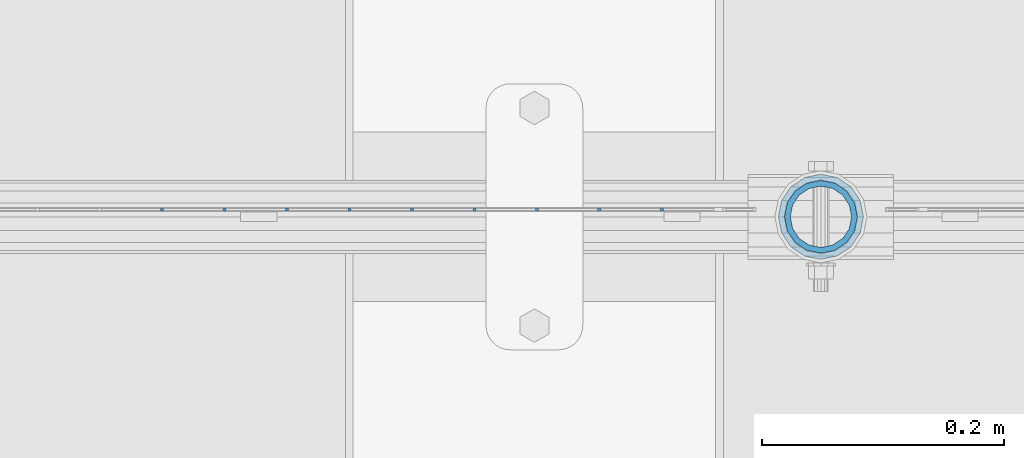
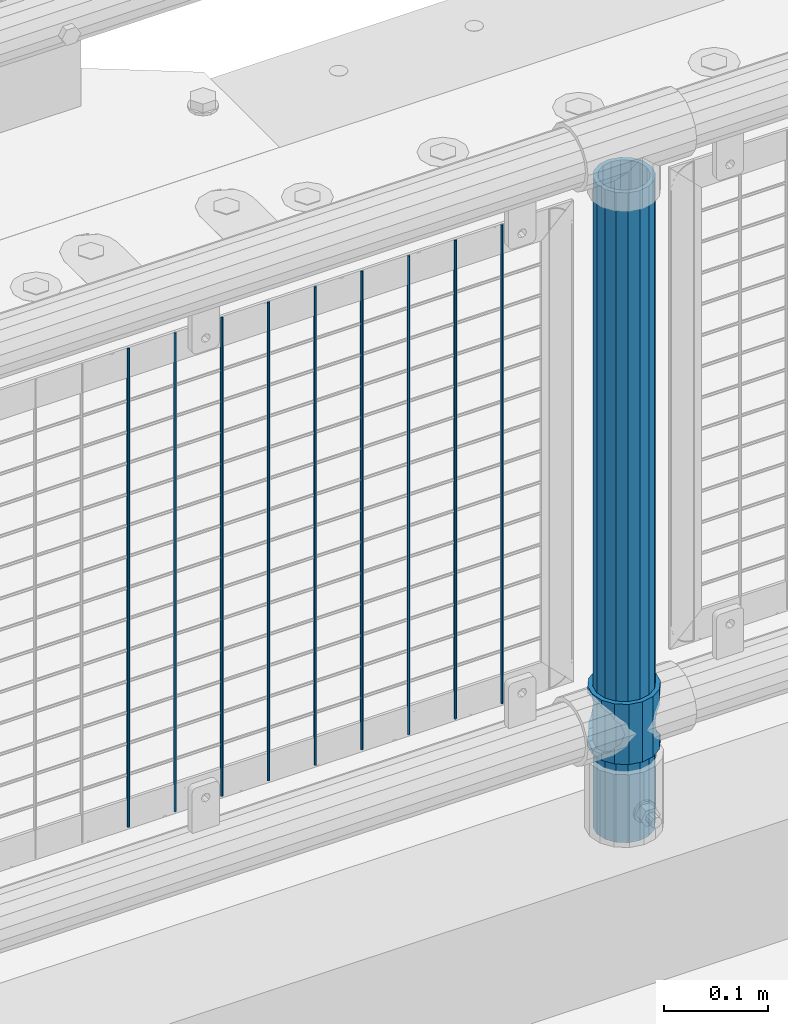
# One storey, part 72 of 240: 11 columns.
"""IFC2X3 building model written with IfcOpenShell, lengths in millimetres."""

from ifc_helpers import new_model, si_unit, frame, origin_with_axes, place, context, subcontext, project, spatial, faceted_brep, material, type_object, element, save


model = new_model("IFC2X3")

# Units and contexts
model_context = context("Model", 3, precision=1e-05, world=origin_with_axes())
body_context = subcontext(model_context, "Body", "Model", "MODEL_VIEW")
ifc_project = project(units=[si_unit("LENGTHUNIT", "METRE", prefix="MILLI"), si_unit("AREAUNIT", "SQUARE_METRE"), si_unit("VOLUMEUNIT", "CUBIC_METRE"), si_unit("MASSUNIT", "GRAM", prefix="KILO"), si_unit("TIMEUNIT", "SECOND"), si_unit("PLANEANGLEUNIT", "RADIAN"), si_unit("SOLIDANGLEUNIT", "STERADIAN"), si_unit("THERMODYNAMICTEMPERATUREUNIT", "DEGREE_CELSIUS"), si_unit("LUMINOUSINTENSITYUNIT", "LUMEN")], contexts=[model_context])

# Site, building, storey
site_placement = place(None, origin_with_axes())
site = spatial("IfcSite", under=ifc_project, at=site_placement, CompositionType="ELEMENT")
building_placement = place(site_placement, origin_with_axes())
building = spatial("IfcBuilding", under=site, at=building_placement, Name="Standard", CompositionType="ELEMENT")
storey_placement = place(building_placement, origin_with_axes())
storey = spatial("IfcBuildingStorey", under=building, at=storey_placement, Name="Undefined", CompositionType="ELEMENT", Elevation=0.0)

# Columns
ifc_material_1 = material(Name="Misc_Undefined")
column_type_1 = type_object("IfcColumnType", PredefinedType="NOTDEFINED")
column_1_placement = place(storey_placement, frame((46387.0, 34664.5, 263.02), z_axis=(-1.0, 0.0, 0.0), x_axis=(0.0, 0.0, 1.0)))
element("IfcColumn", 1, at=column_1_placement, inside=storey, type_object=column_type_1, material=ifc_material_1, context=body_context, shape_type="Brep", body=[
    faceted_brep([(56.6106908090114, 21.4606908090136, -21.4606908090136), (56.6106908090114, 21.4606908090136, -27.1226768591077), (61.9623795176703, 13.4513226476338, -32.4743655677739), (63.1897438117172, 11.6144421722784, -32.8397438117172), (63.1897438117172, 11.6144421722784, -28.0397438117143), (46.7644421722801, 28.0397438117143, -11.6144421722784), (46.7644421722801, 28.0397438117143, -20.0882031229849), (51.5310424079941, 24.8548033587067, -24.8548033587067), (35.1500000000015, 30.35, 0.0), (35.1499999999996, 30.3499999999985, -16.6306603983685), (23.5355578277192, 28.0397438117143, -11.6144421722784), (23.5355578277192, 28.0397438117143, -20.0882031229849), (13.6893091909879, 21.4606908090136, -21.4606908090136), (13.6893091909879, 21.4606908090136, -27.1226768591077), (18.7689575919921, 24.8548033587067, -24.8548033587067), (7.11025618828211, 11.6144421722784, -28.0397438117143), (7.11025618828211, 11.6144421722784, -32.8397438117172), (8.33762048232893, 13.4513226476338, -32.4743655677739), (4.79999999999961, 0.0, -30.3499999999985), (4.79999999999961, 0.0, -35.1500000000015), (7.11025618828211, -11.6144421722784, -28.0397438117143), (7.11025618828211, -11.6144421722784, -32.8397438117245), (13.6893091909879, -21.4606908090136, -21.4606908090136), (13.6893091909879, -21.4606908090136, -27.1226768591223), (8.33762048232455, -13.4513226476338, -32.4743655677739), (23.5355578277191, -28.0397438117143, -11.6144421722784), (23.5355578277191, -28.0397438117143, -20.0882031229994), (18.7689575919987, -24.8548033587067, -24.8548033587067), (35.1500000000015, -30.35, 0.0), (35.1499999999996, -30.3499999999985, -16.6306603983758), (46.7644421722801, -28.0397438117143, -11.6144421722784), (46.7644421722801, -28.0397438117143, -20.0882031229994), (56.6106908090114, -21.4606908090136, -21.4606908090136), (56.6106908090114, -21.4606908090136, -27.1226768591223), (51.5310424080006, -24.8548033587067, -24.8548033587067), (63.1897438117172, -11.6144421722784, -28.0397438117143), (63.1897438117172, -11.6144421722784, -32.8397438117245), (61.9623795176703, -13.4513226476338, -32.4743655677739), (65.4999999999997, 0.0, -30.3499999999985), (65.4999999999997, 0.0, -35.1500000000015), (0.0, -28.0397438117143, -11.6144421722784), (0.0, -30.3499999999985, 0.0), (0.0, -21.4606908090136, -21.4606908090136), (0.0, -11.6144421722784, -28.0397438117143), (0.0, 0.0, -30.3499999999985), (0.0, 11.6144421722784, -28.0397438117143), (0.0, 21.4606908090136, -21.4606908090136), (0.0, 28.0397438117143, -11.6144421722784), (0.0, 30.3499999999985, 0.0), (0.0, 28.0397438117143, 11.6144421722784), (23.5355578277192, 28.0397438117143, 11.6144421722784), (0.0, 21.4606908090136, 21.4606908090136), (13.6893091909879, 21.4606908090136, 21.4606908090136), (0.0, 11.6144421722784, 28.0397438117143), (7.11025618828211, 11.6144421722784, 28.0397438117143), (0.0, 0.0, 30.3499999999985), (4.79999999999961, 0.0, 30.3499999999985), (0.0, -11.6144421722784, 28.0397438117143), (7.11025618828205, -11.6144421722784, 28.0397438117143), (0.0, -21.4606908090136, 21.4606908090136), (13.6893091909879, -21.4606908090136, 21.4606908090136), (0.0, -28.0397438117143, 11.6144421722784), (23.5355578277191, -28.0397438117143, 11.6144421722784), (0.0, -32.4743655677739, 13.4513226476338), (0.0, -35.1500000000015, 0.0), (70.2999999999993, -35.1500000000015, 0.0), (70.2999999999993, -32.4743655677739, 13.4513226476338), (0.0, 13.4513226476338, -32.4743655677739), (0.0, 24.8548033587067, -24.8548033587067), (0.0, 0.0, -35.1500000000015), (0.0, -13.4513226476338, -32.4743655677739), (0.0, -24.8548033587067, -24.8548033587067), (0.0, -24.8548033587067, 24.8548033587067), (0.0, -13.4513226476338, 32.4743655677739), (0.0, 0.0, 35.1500000000015), (0.0, 13.4513226476338, 32.4743655677739), (0.0, 24.8548033587067, 24.8548033587067), (0.0, 32.4743655677739, 13.4513226476338), (0.0, 35.1500000000015, 0.0), (0.0, 32.4743655677739, -13.4513226476338), (0.0, -32.4743655677739, -13.4513226476338), (70.2999999999993, 32.4743655677739, 13.4513226476338), (70.2999999999993, 35.1500000000015, 0.0), (70.2999999999993, 32.4743655677739, -13.4513226476338), (70.2999999999993, 24.8548033587067, -24.8548033587067), (70.2999999999993, 13.4513226476338, -32.4743655677739), (70.2999999999993, 0.0, -35.1500000000015), (70.2999999999993, -13.4513226476338, -32.4743655677739), (70.2999999999993, -24.8548033587067, -24.8548033587067), (70.2999999999993, -32.4743655677739, -13.4513226476338), (70.2999999999993, 28.0397438117143, 11.6144421722784), (70.2999999999993, 21.4606908090136, 21.4606908090136), (56.6106908090114, 21.4606908090136, 21.4606908090136), (46.7644421722801, 28.0397438117143, 11.6144421722784), (70.2999999999993, 11.6144421722784, 28.0397438117143), (63.1897438117172, 11.6144421722784, 28.0397438117143), (70.2999999999993, 0.0, 30.3499999999985), (65.4999999999997, 0.0, 30.3499999999985), (70.2999999999993, -11.6144421722784, 28.0397438117143), (63.1897438117172, -11.6144421722784, 28.0397438117143), (70.2999999999993, -21.4606908090136, 21.4606908090136), (56.6106908090114, -21.4606908090136, 21.4606908090136), (70.2999999999993, -28.0397438117143, 11.6144421722784), (46.7644421722801, -28.0397438117143, 11.6144421722784), (70.2999999999993, -11.6144421722784, -28.0397438117143), (70.2999999999993, 0.0, -30.3499999999985), (70.2999999999993, -21.4606908090136, -21.4606908090136), (70.2999999999993, -28.0397438117143, -11.6144421722784), (70.2999999999993, -30.3499999999985, 0.0), (70.2999999999993, 24.8548033587067, 24.8548033587067), (70.2999999999993, 13.4513226476338, 32.4743655677739), (70.2999999999993, 0.0, 35.1500000000015), (70.2999999999993, -13.4513226476338, 32.4743655677739), (70.2999999999993, -24.8548033587067, 24.8548033587067), (70.2999999999993, 30.3499999999985, 0.0), (70.2999999999993, 28.0397438117143, -11.6144421722784), (70.2999999999993, 21.4606908090136, -21.4606908090136), (70.2999999999993, 11.6144421722784, -28.0397438117143), (61.9623795176742, 13.4513226476338, 32.4743655677739), (51.5310424079941, 24.8548033587067, 24.8548033587067), (56.6106908090114, 21.4606908090136, 27.1226768591077), (65.4999999999997, 0.0, 35.1500000000015), (63.1897438117172, 11.6144421722784, 32.8397438117172), (63.1897438117172, -11.6144421722784, 32.8397438117172), (61.9623795176698, -13.4513226476338, 32.4743655677739), (56.6106908090114, -21.4606908090136, 27.1226768591005), (51.5310424080006, -24.8548033587067, 24.8548033587067), (18.7689575919987, -24.8548033587067, 24.8548033587067), (46.7644421722801, -28.0397438117143, 20.0882031229994), (35.1499999999996, -30.3499999999985, 16.6306603983758), (23.5355578277191, -28.0397438117143, 20.0882031229994), (8.33762048232506, -13.4513226476338, 32.4743655677739), (13.6893091909879, -21.4606908090136, 27.1226768591005), (4.79999999999961, 0.0, 35.1500000000015), (7.11025618828205, -11.6144421722784, 32.8397438117172), (7.11025618828211, 11.6144421722784, 32.8397438117172), (8.33762048232506, 13.4513226476338, 32.4743655677739), (13.6893091909879, 21.4606908090136, 27.1226768591077), (18.7689575919856, 24.8548033587067, 24.8548033587067), (23.5355578277192, 28.0397438117143, 20.0882031229994), (35.1499999999996, 30.3499999999985, 16.6306603983758), (46.7644421722801, 28.0397438117143, 20.0882031229994)], [[[0, 1, 2, 3, 4]], [[5, 6, 7, 1, 0]], [[8, 9, 6, 5]], [[10, 11, 9, 8]], [[12, 13, 14, 11, 10]], [[15, 16, 17, 13, 12]], [[18, 19, 16, 15]], [[20, 21, 19, 18]], [[22, 23, 24, 21, 20]], [[25, 26, 27, 23, 22]], [[28, 29, 26, 25]], [[30, 31, 29, 28]], [[32, 33, 34, 31, 30]], [[35, 36, 37, 33, 32]], [[38, 39, 36, 35]], [[4, 3, 39, 38]], [[40, 41, 28, 25]], [[42, 40, 25, 22]], [[43, 42, 22, 20]], [[44, 43, 20, 18]], [[45, 44, 18, 15]], [[46, 45, 15, 12]], [[47, 46, 12, 10]], [[48, 47, 10, 8]], [[49, 48, 8, 50]], [[51, 49, 50, 52]], [[53, 51, 52, 54]], [[55, 53, 54, 56]], [[57, 55, 56, 58]], [[59, 57, 58, 60]], [[61, 59, 60, 62]], [[41, 61, 62, 28]], [[63, 64, 65, 66]], [[17, 67, 68, 14, 13]], [[19, 69, 67, 17, 16]], [[70, 69, 19, 21, 24]], [[71, 70, 24, 23, 27]], [[63, 72, 73, 74, 75, 76, 77, 78, 79, 68, 67, 69, 70, 71, 80, 64], [40, 42, 43, 44, 45, 46, 47, 48, 49, 51, 53, 55, 57, 59, 61, 41]], [[78, 77, 81, 82]], [[79, 78, 82, 83]], [[14, 68, 79, 83, 84, 7, 6, 9, 11]], [[84, 85, 2, 1, 7]], [[85, 86, 39, 3, 2]], [[37, 87, 88, 34, 33]], [[39, 86, 87, 37, 36]], [[34, 88, 89, 80, 71, 27, 26, 29, 31]], [[64, 80, 89, 65]], [[90, 91, 92, 93]], [[91, 94, 95, 92]], [[94, 96, 97, 95]], [[96, 98, 99, 97]], [[98, 100, 101, 99]], [[100, 102, 103, 101]], [[104, 105, 38, 35]], [[106, 104, 35, 32]], [[107, 106, 32, 30]], [[108, 107, 30, 28]], [[102, 108, 28, 103]], [[88, 87, 86, 85, 84, 83, 82, 81, 109, 110, 111, 112, 113, 66, 65, 89], [100, 98, 96, 94, 91, 90, 114, 115, 116, 117, 105, 104, 106, 107, 108, 102]], [[118, 110, 109, 119, 120]], [[121, 111, 110, 118, 122]], [[112, 111, 121, 123, 124]], [[113, 112, 124, 125, 126]], [[127, 72, 63, 66, 113, 126, 128, 129, 130]], [[131, 73, 72, 127, 132]], [[133, 74, 73, 131, 134]], [[75, 74, 133, 135, 136]], [[76, 75, 136, 137, 138]], [[119, 109, 81, 77, 76, 138, 139, 140, 141]], [[92, 120, 119, 141, 93]], [[95, 122, 118, 120, 92]], [[97, 121, 122, 95]], [[99, 123, 121, 97]], [[101, 125, 124, 123, 99]], [[103, 128, 126, 125, 101]], [[28, 129, 128, 103]], [[62, 130, 129, 28]], [[60, 132, 127, 130, 62]], [[58, 134, 131, 132, 60]], [[56, 133, 134, 58]], [[54, 135, 133, 56]], [[52, 137, 136, 135, 54]], [[50, 139, 138, 137, 52]], [[8, 140, 139, 50]], [[93, 141, 140, 8]], [[114, 90, 93, 8]], [[115, 114, 8, 5]], [[116, 115, 5, 0]], [[117, 116, 0, 4]], [[105, 117, 4, 38]]]),
])
ifc_material_2 = material()
column_type_2 = type_object("IfcColumnType", PredefinedType="NOTDEFINED")
column_2_placement = place(storey_placement, frame((46387.0, 34664.5, 168.02), z_axis=(-1.0, 0.0, 0.0), x_axis=(0.0, 0.0, 1.0)))
element("IfcColumn", 2, at=column_2_placement, inside=storey, type_object=column_type_2, material=ifc_material_2, context=body_context, shape_type="Brep", body=[
    faceted_brep([(0.0, -25.3499999999985, 0.0), (0.0, -23.4203461491634, 9.70102501045767), (760.0, -23.4203461491634, 9.70102501045767), (760.0, -25.3499999999985, 0.0), (0.0, -17.9251569030821, 17.9251569030821), (760.0, -17.9251569030821, 17.9251569030821), (0.0, -9.70102501045767, 23.4203461491634), (760.0, -9.70102501045767, 23.4203461491634), (0.0, 0.0, 25.3499999999985), (760.0, 0.0, 25.3499999999985), (0.0, 9.70102501045767, 23.4203461491634), (760.0, 9.70102501045767, 23.4203461491634), (0.0, 17.9251569030821, 17.9251569030821), (760.0, 17.9251569030821, 17.9251569030821), (0.0, 23.4203461491634, 9.70102501045767), (760.0, 23.4203461491634, 9.70102501045767), (0.0, 25.3499999999985, 0.0), (760.0, 25.3499999999985, 0.0), (0.0, 23.4203461491634, -9.70102501045767), (760.0, 23.4203461491634, -9.70102501045767), (0.0, 17.9251569030821, -17.9251569030821), (760.0, 17.9251569030821, -17.9251569030821), (0.0, 9.70102501045767, -23.4203461491634), (760.0, 9.70102501045767, -23.4203461491634), (0.0, 0.0, -25.3499999999985), (760.0, 0.0, -25.3499999999985), (0.0, -9.70102501045767, -23.4203461491634), (760.0, -9.70102501045767, -23.4203461491634), (0.0, -17.9251569030821, -17.9251569030821), (760.0, -17.9251569030821, -17.9251569030821), (0.0, -23.4203461491634, -9.70102501045767), (760.0, -23.4203461491634, -9.70102501045767), (0.0, -30.1500000000015, 0.0), (0.0, -27.8549679052157, -11.5379054858058), (760.0, -27.8549679052157, -11.5379054858058), (760.0, -30.1500000000015, 0.0), (0.0, -21.3192694527752, -21.3192694527752), (760.0, -21.3192694527752, -21.3192694527752), (0.0, -11.5379054858058, -27.8549679052157), (760.0, -11.5379054858058, -27.8549679052157), (0.0, 0.0, -30.1500000000015), (760.0, 0.0, -30.1500000000015), (0.0, 11.5379054858058, -27.8549679052157), (760.0, 11.5379054858058, -27.8549679052157), (0.0, 21.3192694527752, -21.3192694527752), (760.0, 21.3192694527752, -21.3192694527752), (0.0, 27.8549679052157, -11.5379054858058), (760.0, 27.8549679052157, -11.5379054858058), (0.0, 30.1500000000015, 0.0), (760.0, 30.1500000000015, 0.0), (0.0, 27.8549679052157, 11.5379054858058), (760.0, 27.8549679052157, 11.5379054858058), (0.0, 21.3192694527752, 21.3192694527752), (760.0, 21.3192694527752, 21.3192694527752), (0.0, 11.5379054858058, 27.8549679052157), (760.0, 11.5379054858058, 27.8549679052157), (0.0, 0.0, 30.1500000000015), (760.0, 0.0, 30.1500000000015), (0.0, -11.5379054858058, 27.8549679052157), (760.0, -11.5379054858058, 27.8549679052157), (0.0, -21.3192694527752, 21.3192694527752), (760.0, -21.3192694527752, 21.3192694527752), (0.0, -27.8549679052157, 11.5379054858058), (760.0, -27.8549679052157, 11.5379054858058)], [[[0, 1, 2, 3]], [[1, 4, 5, 2]], [[4, 6, 7, 5]], [[6, 8, 9, 7]], [[8, 10, 11, 9]], [[10, 12, 13, 11]], [[12, 14, 15, 13]], [[14, 16, 17, 15]], [[16, 18, 19, 17]], [[18, 20, 21, 19]], [[20, 22, 23, 21]], [[22, 24, 25, 23]], [[24, 26, 27, 25]], [[26, 28, 29, 27]], [[28, 30, 31, 29]], [[30, 0, 3, 31]], [[32, 33, 34, 35]], [[33, 36, 37, 34]], [[36, 38, 39, 37]], [[38, 40, 41, 39]], [[40, 42, 43, 41]], [[42, 44, 45, 43]], [[44, 46, 47, 45]], [[46, 48, 49, 47]], [[48, 50, 51, 49]], [[50, 52, 53, 51]], [[52, 54, 55, 53]], [[54, 56, 57, 55]], [[56, 58, 59, 57]], [[58, 60, 61, 59]], [[60, 62, 63, 61]], [[62, 32, 35, 63]], [[37, 39, 41, 43, 45, 47, 49, 51, 53, 55, 57, 59, 61, 63, 35, 34], [5, 7, 9, 11, 13, 15, 17, 19, 21, 23, 25, 27, 29, 31, 3, 2]], [[62, 60, 58, 56, 54, 52, 50, 48, 46, 44, 42, 40, 38, 36, 33, 32], [30, 28, 26, 24, 22, 20, 18, 16, 14, 12, 10, 8, 6, 4, 1, 0]]]),
])
column_type_3 = type_object("IfcColumnType", Name="D3", PredefinedType="NOTDEFINED")
for number, where, z_axis, x_axis in (
    (3, (46255.34, 34670.5, 353.02), (-1.0, 0.0, 0.0), (0.0, 0.0, 1.0)),
    (4, (46203.685, 34670.5, 353.02), (-1.0, 0.0, 0.0), (0.0, 0.0, 1.0)),
    (5, (46152.03, 34670.5, 353.02), (-1.0, 0.0, 0.0), (0.0, 0.0, 1.0)),
    (6, (46100.375, 34670.5, 353.02), (-1.0, 0.0, 0.0), (0.0, 0.0, 1.0)),
    (7, (46048.72, 34670.5, 353.02), (-1.0, 0.0, 0.0), (0.0, 0.0, 1.0)),
    (8, (45997.065, 34670.5, 353.02), (-1.0, 0.0, 0.0), (0.0, 0.0, 1.0)),
    (9, (45945.41, 34670.5, 353.02), (-1.0, 0.0, 0.0), (0.0, 0.0, 1.0)),
    (10, (45893.755, 34670.5, 353.02), (-1.0, 0.0, 0.0), (0.0, 0.0, 1.0)),
    (11, (45842.1, 34670.5, 353.02), (-1.0, 0.0, 0.0), (0.0, 0.0, 1.0)),
):
    element("IfcColumn", number, at=place(storey_placement, frame(where, z_axis=z_axis, x_axis=x_axis)), inside=storey, type_object=column_type_3, material=ifc_material_1, ObjectType="D3", context=body_context, shape_type="Brep", body=[
        faceted_brep([(-7.27595761418343e-12, -1.49999999999272, 0.0), (-7.27595761418343e-12, -0.749999999992724, -1.29903810567669), (560.0, -0.75, -1.29903810567339), (560.0, -1.5, 0.0), (0.0, 0.750000000007276, -1.29903810567669), (560.0, 0.75, -1.29903810567339), (0.0, 1.50000000000728, 0.0), (560.0, 1.5, 0.0), (0.0, 0.750000000007276, 1.29903810567669), (560.0, 0.75, 1.29903810567339), (-7.27595761418343e-12, -0.749999999992724, 1.29903810567669), (560.0, -0.75, 1.29903810567339)], [[[0, 1, 2, 3]], [[1, 4, 5, 2]], [[4, 6, 7, 5]], [[6, 8, 9, 7]], [[8, 10, 11, 9]], [[10, 0, 3, 11]], [[5, 7, 9, 11, 3, 2]], [[10, 8, 6, 4, 1, 0]]]),
    ])

save(model, "model.ifc")
